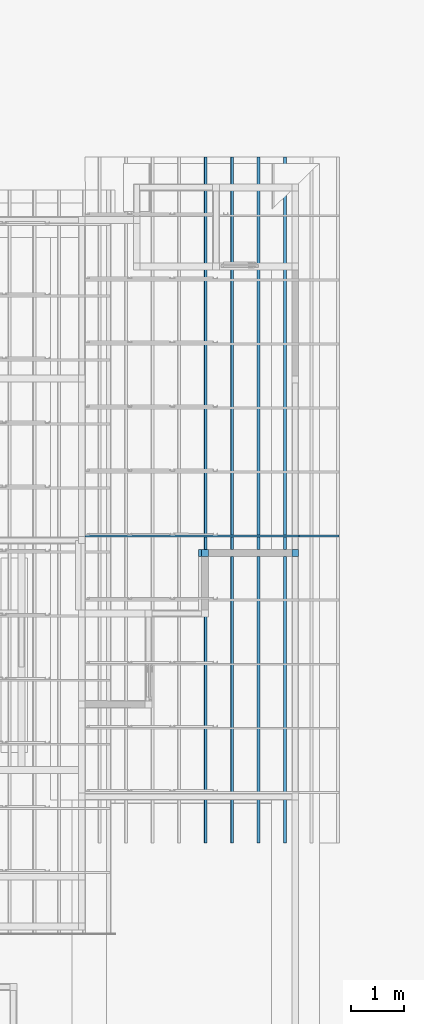
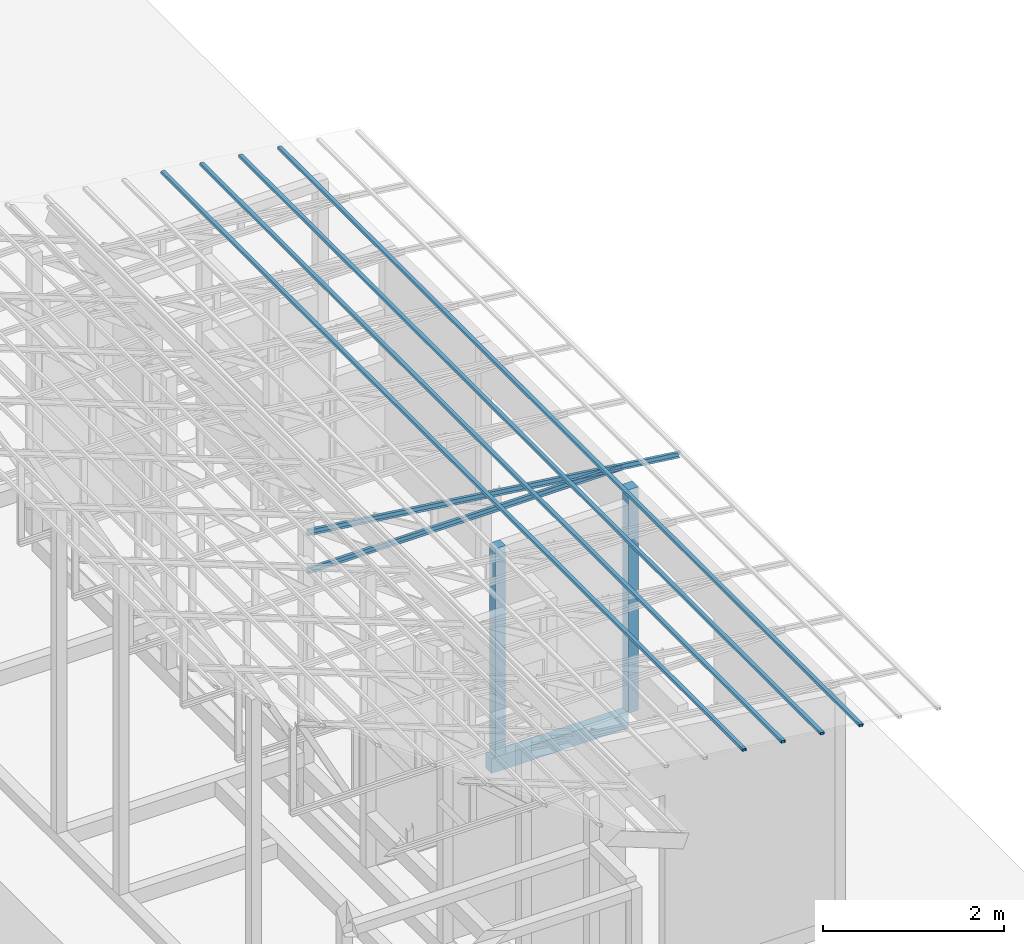
# One storey, part 10 of 22: 6 members, 3 beams, 1 element without a shape of its own.
"""IFC4 building model written with IfcOpenShell, lengths in millimetres."""

from ifc_helpers import new_model, entity, si_unit, converted_unit, frame, origin_with_axes, origin_2d_with_axis, place, context, subcontext, project, spatial, indexed_curve, rectangle, hollow_rectangle, c_section, outline, extrude, material, material_profile, profile_set, profile_usage, type_object, element, aggregate, save


model = new_model("IFC4")

# Units and contexts
model_context = context("Model", 3, precision=1e-05, world=origin_with_axes())
plan_context = context("Plan", 2, precision=1e-05, world=origin_2d_with_axis())
body_context = subcontext(model_context, "Body", "Model", "MODEL_VIEW")
ifc_project = project(units=[si_unit("VOLUMEUNIT", "CUBIC_METRE"), si_unit("LENGTHUNIT", "METRE", prefix="MILLI"), si_unit("AREAUNIT", "SQUARE_METRE"), converted_unit("PLANEANGLEUNIT", "degree", entity("IfcReal", 0.0174532925199433), si_unit("PLANEANGLEUNIT", "RADIAN"), dimensions=[0, 0, 0, 0, 0, 0, 0])], contexts=[model_context, plan_context])

# Site, building, storey
site_placement = place(None, origin_with_axes())
site = spatial("IfcSite", under=ifc_project, at=site_placement)
building_placement = place(site_placement, origin_with_axes())
building = spatial("IfcBuilding", under=site, at=building_placement, Name="2")
storey_placement = place(building_placement, frame((0.0, 0.0, 200.000002980232), z_axis=(0.0, 0.0, 1.0), x_axis=(1.0, 0.0, 0.0)))
storey = spatial("IfcBuildingStorey", under=building, at=storey_placement)

# Beams
ifc_material_1 = material(Name="Concrete")
ifc_material_profile_1 = material_profile(ifc_material_1, outline(indexed_curve([(-65.0, 99.9999923706055), (65.0, 99.9999923706055), (65.0, -99.9999923706055), (-65.0, -99.9999923706055), (-65.0, 99.9999923706055)])))
ifc_profile_set_1 = profile_set([ifc_material_profile_1])
ifc_profile_usage_1 = profile_usage(ifc_profile_set_1, cardinal=2)
beam_type_1 = type_object("IfcBeamType", PredefinedType="BEAM", material=ifc_profile_set_1)
beam_1_placement = place(storey_placement, frame((-1810.00018119812, 11065.0014877319, -200.000347937447), z_axis=(0.999999999999962, -1.94707169498535e-07, 1.9470718370939e-07), x_axis=(1.94707183709392e-07, 0.999999999999974, -1.19209289550778e-07)))
element("IfcBeam", 1, at=beam_1_placement, inside=storey, type_object=beam_type_1, material=ifc_profile_usage_1, Name="Beam", PredefinedType="BEAM", context=body_context, shape_type="SweptSolid", body=[
    extrude(outline(indexed_curve([(-65.0, 99.9999923706055), (65.0, 99.9999923706055), (65.0, -99.9999923706055), (-65.0, -99.9999923706055), (-65.0, 99.9999923706055)])), frame((0.0, 100.0, 0.0), z_axis=(0.0, 0.0, 1.0), x_axis=(1.0, 0.0, 0.0)), (0.0, 0.0, 1.0), 1745.00167114269),
])
ifc_material_profile_2 = material_profile(ifc_material_1, rectangle(XDim=130.000015258789, YDim=130.000015258789, kind="CURVE"))
ifc_profile_set_2 = profile_set([ifc_material_profile_2])
ifc_profile_usage_2 = profile_usage(ifc_profile_set_2, cardinal=5)
beam_type_2 = type_object("IfcBeamType", PredefinedType="BEAM", material=ifc_profile_set_2)
beam_2_placement = place(storey_placement, frame((0.00166893005371094, 11064.9995803833, 0.00216066837310791), z_axis=(0.0, 0.0, 1.0), x_axis=(1.0, 0.0, 0.0)))
element("IfcBeam", 2, at=beam_2_placement, inside=storey, type_object=beam_type_2, material=ifc_profile_usage_2, Name="Column", PredefinedType="BEAM", context=body_context, shape_type="SweptSolid", body=[
    extrude(rectangle(XDim=130.000015258789, YDim=130.000015258789, kind="CURVE"), origin_with_axes(), (0.0, 0.0, 1.0), 3010.00912205527),
])
ifc_profile_usage_3 = profile_usage(ifc_profile_set_2, cardinal=5)
beam_3_placement = place(storey_placement, frame((-1695.00029087067, 11064.998626709, -0.000312924384848756), z_axis=(0.0, 0.0, 1.0), x_axis=(1.0, 0.0, 0.0)))
element("IfcBeam", 3, at=beam_3_placement, inside=storey, type_object=beam_type_2, material=ifc_profile_usage_3, Name="Column", PredefinedType="BEAM", context=body_context, shape_type="SweptSolid", body=[
    extrude(rectangle(XDim=130.000015258789, YDim=130.000015258789, kind="CURVE"), origin_with_axes(), (0.0, 0.0, 1.0), 2811.24400598303),
])

# Assembly, members
assembly_placement = place(storey_placement, frame((-1561.45393848419, 6600.0657081604, 3019.63977515697), z_axis=(0.0, 0.0, 1.0), x_axis=(1.0, 0.0, 0.0)))
assembly = element("IfcElementAssembly", 4, at=assembly_placement, inside=storey, Name="K1")
ifc_material_2 = material(Name="STEEL")
ifc_material_profile_3 = material_profile(ifc_material_2, c_section(Depth=75.0, Width=35.0, WallThickness=1.0, Girth=1.0, kind="CURVE"))
ifc_profile_set_3 = profile_set([ifc_material_profile_3])
ifc_profile_usage_4 = profile_usage(ifc_profile_set_3, cardinal=9)
member_type_1 = type_object("IfcMemberType", Name="C75", PredefinedType="CHORD", material=ifc_profile_set_3)
member_1_placement = place(assembly_placement, frame((1634.4433426857, 4798.93255233765, 64.9838447570801), z_axis=(-0.999999999999996, -7.54978941586157e-08, -4.37113882867378e-08), x_axis=(7.54979012640425e-08, -0.999999999999989, -1.2785038450147e-07)))
member_1 = element("IfcMember", 5, at=member_1_placement, type_object=member_type_1, material=ifc_profile_usage_4, Name="Member", context=body_context, shape_type="SweptSolid", body=[
    extrude(c_section(Depth=75.0, Width=35.0, WallThickness=1.0, Girth=1.0, kind="CURVE"), frame((17.5, -37.5, 0.0), z_axis=(0.0, 0.0, 1.0), x_axis=(1.0, 0.0, 0.0)), (0.0, 0.0, 1.0), 4007.95455591631),
])
ifc_profile_usage_5 = profile_usage(ifc_profile_set_3, cardinal=9)
member_2_placement = place(assembly_placement, frame((2381.98524713516, 4798.93255233765, -28.5120010375977), z_axis=(-0.991864132670109, -9.11591360127481e-08, 0.127300991050989), x_axis=(7.54979012640425e-08, -0.999999999999989, -1.2785038450147e-07)))
member_2 = element("IfcMember", 6, at=member_2_placement, type_object=member_type_1, material=ifc_profile_usage_5, Name="Member", context=body_context, shape_type="SweptSolid", body=[
    extrude(c_section(Depth=75.0, Width=35.0, WallThickness=1.0, Girth=1.0, kind="CURVE"), frame((17.5, -37.5, 0.0), z_axis=(0.0, 0.0, 1.0), x_axis=(1.0, 0.0, 0.0)), (0.0, 0.0, 1.0), 4790.46084290085),
])
aggregate(assembly, [member_1, member_2])

# Members
ifc_material_profile_4 = material_profile(ifc_material_2, hollow_rectangle(XDim=50.0, YDim=33.0, WallThickness=1.0, InnerFilletRadius=1.0, OuterFilletRadius=0.0, kind="CURVE"))
ifc_profile_set_4 = profile_set([ifc_material_profile_4])
ifc_profile_usage_6 = profile_usage(ifc_profile_set_4, cardinal=3)
member_type_2 = type_object("IfcMemberType", PredefinedType="CHORD", material=ifc_profile_set_4)
member_3_placement = place(storey_placement, frame((-171.363115310669, 5634.99975204468, 3118.1924790144), z_axis=(5.55417489778164e-09, 0.999999999999999, 4.33570832569785e-08), x_axis=(-0.99189443015292, 0.0, 0.127064705688141)))
element("IfcMember", 7, at=member_3_placement, inside=storey, type_object=member_type_2, material=ifc_profile_usage_6, Name="Member", context=body_context, shape_type="SweptSolid", body=[
    extrude(hollow_rectangle(XDim=50.0, YDim=33.0, WallThickness=1.0, InnerFilletRadius=1.0, OuterFilletRadius=0.0, kind="CURVE"), frame((25.0, 16.5, 0.0), z_axis=(0.0, 0.0, 1.0), x_axis=(1.0, 0.0, 0.0)), (0.0, 0.0, 1.0), 12845.0009370286),
])
ifc_profile_usage_7 = profile_usage(ifc_profile_set_4, cardinal=3)
member_4_placement = place(storey_placement, frame((-667.310297489166, 5634.99975204468, 3181.72483146191), z_axis=(5.55417489778164e-09, 0.999999999999999, 4.33570832569785e-08), x_axis=(-0.99189443015292, 0.0, 0.127064705688141)))
element("IfcMember", 8, at=member_4_placement, inside=storey, type_object=member_type_2, material=ifc_profile_usage_7, Name="Member", context=body_context, shape_type="SweptSolid", body=[
    extrude(hollow_rectangle(XDim=50.0, YDim=33.0, WallThickness=1.0, InnerFilletRadius=1.0, OuterFilletRadius=0.0, kind="CURVE"), frame((25.0, 16.5, 0.0), z_axis=(0.0, 0.0, 1.0), x_axis=(1.0, 0.0, 0.0)), (0.0, 0.0, 1.0), 12845.0009370286),
])
ifc_profile_usage_8 = profile_usage(ifc_profile_set_4, cardinal=3)
member_5_placement = place(storey_placement, frame((-1163.25759887695, 5634.99975204468, 3245.25718390942), z_axis=(5.55417489778164e-09, 0.999999999999999, 4.33570832569785e-08), x_axis=(-0.99189443015292, 0.0, 0.127064705688141)))
element("IfcMember", 9, at=member_5_placement, inside=storey, type_object=member_type_2, material=ifc_profile_usage_8, Name="Member", context=body_context, shape_type="SweptSolid", body=[
    extrude(hollow_rectangle(XDim=50.0, YDim=33.0, WallThickness=1.0, InnerFilletRadius=1.0, OuterFilletRadius=0.0, kind="CURVE"), frame((25.0, 16.5, 0.0), z_axis=(0.0, 0.0, 1.0), x_axis=(1.0, 0.0, 0.0)), (0.0, 0.0, 1.0), 12845.0009370286),
])
ifc_profile_usage_9 = profile_usage(ifc_profile_set_4, cardinal=3)
member_6_placement = place(storey_placement, frame((-1659.20472145081, 5634.99975204468, 3308.78953635693), z_axis=(5.55417489778164e-09, 0.999999999999999, 4.33570832569785e-08), x_axis=(-0.99189443015292, 0.0, 0.127064705688141)))
element("IfcMember", 10, at=member_6_placement, inside=storey, type_object=member_type_2, material=ifc_profile_usage_9, Name="Member", context=body_context, shape_type="SweptSolid", body=[
    extrude(hollow_rectangle(XDim=50.0, YDim=33.0, WallThickness=1.0, InnerFilletRadius=1.0, OuterFilletRadius=0.0, kind="CURVE"), frame((25.0, 16.5, 0.0), z_axis=(0.0, 0.0, 1.0), x_axis=(1.0, 0.0, 0.0)), (0.0, 0.0, 1.0), 12845.0009370286),
])

save(model, "model.ifc")
